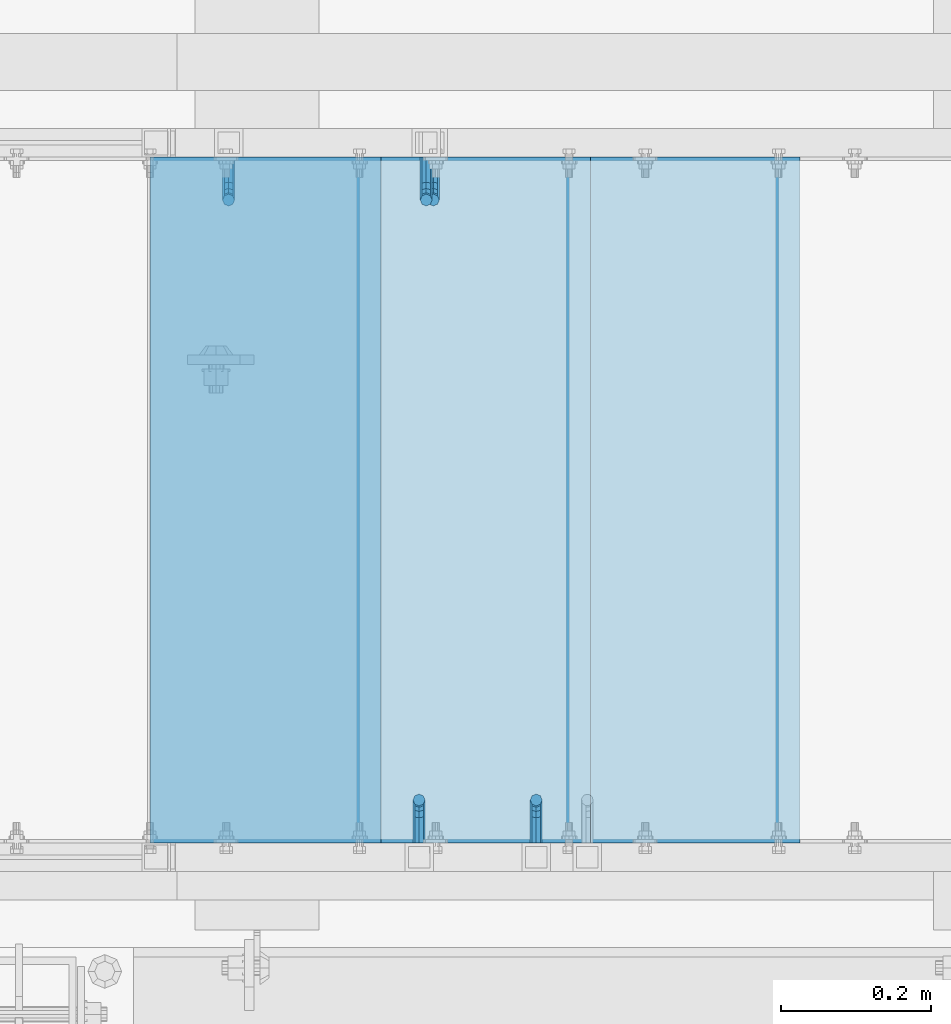
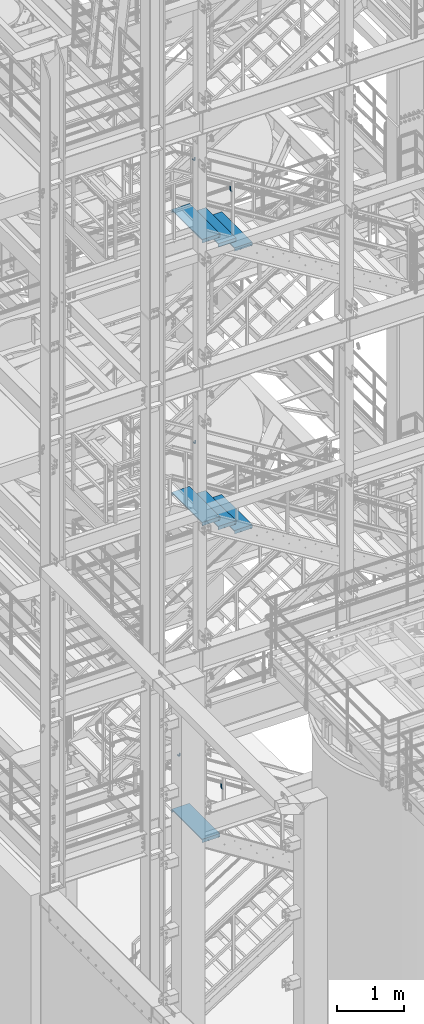
# One storey, part 1141 of 1876: 12 beams, 8 elements without a shape of their own.
"""IFC2X3 building model written with IfcOpenShell, lengths in millimetres."""

from ifc_helpers import new_model, si_unit, frame, origin_with_axes, place, context, subcontext, project, spatial, faceted_brep, material, type_object, element, aggregate, save


model = new_model("IFC2X3")

# Units and contexts
model_context = context("Model", 3, precision=1e-05, world=origin_with_axes())
body_context = subcontext(model_context, "Body", "Model", "MODEL_VIEW")
ifc_project = project(units=[si_unit("LENGTHUNIT", "METRE", prefix="MILLI"), si_unit("AREAUNIT", "SQUARE_METRE"), si_unit("VOLUMEUNIT", "CUBIC_METRE"), si_unit("MASSUNIT", "GRAM", prefix="KILO"), si_unit("TIMEUNIT", "SECOND"), si_unit("PLANEANGLEUNIT", "RADIAN"), si_unit("SOLIDANGLEUNIT", "STERADIAN"), si_unit("THERMODYNAMICTEMPERATUREUNIT", "DEGREE_CELSIUS"), si_unit("LUMINOUSINTENSITYUNIT", "LUMEN")], contexts=[model_context])

# Site, building, storey
site_placement = place(None, origin_with_axes())
site = spatial("IfcSite", under=ifc_project, at=site_placement, CompositionType="ELEMENT")
building_placement = place(site_placement, origin_with_axes())
building = spatial("IfcBuilding", under=site, at=building_placement, Name="Undefined", CompositionType="ELEMENT")
storey_placement = place(building_placement, origin_with_axes())
storey = spatial("IfcBuildingStorey", under=building, at=storey_placement, Name="Undefined", CompositionType="ELEMENT", Elevation=0.0)

# Assembly, beam
assembly_1_placement = place(storey_placement, origin_with_axes())
assembly_1 = element("IfcElementAssembly", 1, at=assembly_1_placement, inside=storey, Name="RAIL", AssemblyPlace="NOTDEFINED", PredefinedType="RIGID_FRAME")
ifc_material = material(Name="STEEL/A36")
beam_type_1 = type_object("IfcBeamType", PredefinedType="NOTDEFINED")
beam_1_placement = place(assembly_1_placement, frame((3073.40000611553, -6883.39999893226, 5224.5870754085), z_axis=(-1.0, 0.0, 0.0), x_axis=(0.0, 1.0, 0.0)))
beam_1 = element("IfcBeam", 2, at=beam_1_placement, type_object=beam_type_1, material=ifc_material, Name="BRACKET", context=body_context, shape_type="Brep", body=[
    faceted_brep([(0.0, -5.61266007566822, 5.61266007566883), (0.0, 0.0, 7.9375), (0.0, 5.61266007566822, 5.61266007566883), (0.0, 7.9375, 0.0), (0.0, 5.61266007566822, -5.61266007566883), (0.0, 0.0, -7.9375), (0.0, -5.61266007566822, -5.61266007566883), (0.0, -7.9375, 0.0), (23.8125, 5.61266007566883, 5.61266007566792), (23.8125, 7.9375, 0.0), (23.8125, 5.61266007566883, -5.61266007566792), (23.8125, 0.0, -7.9375), (23.8125, -5.61266007566883, -5.61266007566792), (23.8125, -7.9375, 0.0), (23.8125, -5.61266007566883, 5.61266007566792), (23.8125, 0.0, 7.9375), (36.5702095103989, -2.53766620105534, 7.9375), (38.7180815328547, 2.64775556579752, 5.61266007566792), (39.6077592547972, 4.79562758825296, 0.0), (38.7180815328547, 2.64775556579752, -5.61266007566792), (36.5702095103989, -2.53766620105534, -7.9375), (34.4223374879439, -7.72308796790867, -5.61266007566792), (33.5326597660014, -9.87095999036364, 0.0), (34.4223374879439, -7.72308796790867, 5.61266007566792), (43.4169233967659, -13.733078129113, 5.61266007566792), (47.385673396765, -9.76432812911298, 7.9375), (41.7730133210971, -15.3769882047809, 0.0), (43.4169233967659, -13.733078129113, -5.61266007566792), (47.385673396765, -9.76432812911298, -7.9375), (51.354423396765, -5.79557812911253, -5.61266007566792), (52.9983334724338, -4.15166805344461, 0.0), (51.354423396765, -5.79557812911253, 5.61266007566792), (54.6123353248231, -20.5797920154787, 7.9375), (59.7977570916764, -18.4319199930233, 5.61266007566792), (49.4269135579698, -22.7276640379341, 5.61266007566792), (47.2790415355148, -23.6173417598766, 0.0), (49.4269135579698, -22.7276640379341, -5.61266007566792), (54.6123353248231, -20.5797920154787, -7.9375), (59.7977570916764, -18.4319199930233, -5.61266007566792), (61.9456291141314, -17.5422422710808, 0.0), (62.7626616015468, -33.3375015258789, 5.61266007566792), (65.0875015258789, -33.3375015258789, 0.0), (57.1500015258789, -33.3375015258789, 7.9375), (51.5373414502101, -33.3375015258789, 5.61266007566792), (49.2125015258789, -33.3375015258789, 0.0), (51.5373414502101, -33.3375015258789, -5.61266007566792), (57.1500015258789, -33.3375015258789, -7.9375), (62.7626616015468, -33.3375015258789, -5.61266007566792), (65.0875015258789, -66.3399314131093, 0.0), (62.7626616015468, -62.779234846751, -5.61266007566792), (57.1500015258789, -61.3043460374702, -7.9375), (51.537341450211, -62.779234846751, -5.61266007566792), (49.2125015258789, -66.3399314131093, 0.0), (51.537341450211, -69.9006279794671, 5.61266007566792), (57.1500015258789, -71.375516788748, 7.9375), (62.7626616015468, -69.9006279794671, 5.61266007566792)], [[[0, 1, 2, 3, 4, 5, 6, 7]], [[3, 2, 8, 9]], [[4, 3, 9, 10]], [[5, 4, 10, 11]], [[6, 5, 11, 12]], [[7, 6, 12, 13]], [[0, 7, 13, 14]], [[1, 0, 14, 15]], [[2, 1, 15, 8]], [[8, 15, 16, 17]], [[9, 8, 17, 18]], [[10, 9, 18, 19]], [[11, 10, 19, 20]], [[12, 11, 20, 21]], [[13, 12, 21, 22]], [[14, 13, 22, 23]], [[15, 14, 23, 16]], [[23, 24, 25, 16]], [[22, 26, 24, 23]], [[21, 27, 26, 22]], [[20, 28, 27, 21]], [[19, 29, 28, 20]], [[18, 30, 29, 19]], [[17, 31, 30, 18]], [[16, 25, 31, 17]], [[25, 32, 33, 31]], [[24, 34, 32, 25]], [[26, 35, 34, 24]], [[27, 36, 35, 26]], [[28, 37, 36, 27]], [[29, 38, 37, 28]], [[30, 39, 38, 29]], [[31, 33, 39, 30]], [[33, 40, 41, 39]], [[32, 42, 40, 33]], [[34, 43, 42, 32]], [[35, 44, 43, 34]], [[36, 45, 44, 35]], [[37, 46, 45, 36]], [[38, 47, 46, 37]], [[39, 41, 47, 38]], [[47, 41, 48, 49]], [[46, 47, 49, 50]], [[45, 46, 50, 51]], [[44, 45, 51, 52]], [[43, 44, 52, 53]], [[42, 43, 53, 54]], [[40, 42, 54, 55]], [[41, 40, 55, 48]], [[54, 53, 52, 51, 50, 49, 48, 55]]]),
])
aggregate(assembly_1, [beam_1])

assembly_2_placement = place(storey_placement, origin_with_axes())
assembly_2 = element("IfcElementAssembly", 3, at=assembly_2_placement, inside=storey, Name="RAIL", AssemblyPlace="NOTDEFINED", PredefinedType="RIGID_FRAME")
beam_2_placement = place(assembly_2_placement, frame((3092.45000068742, -5969.00000114554, 11007.9367081082), z_axis=(-1.0, 0.0, 0.0), x_axis=(0.0, -1.0, 0.0)))
beam_2 = element("IfcBeam", 4, at=beam_2_placement, type_object=beam_type_1, material=ifc_material, Name="BRACKET", context=body_context, shape_type="Brep", body=[
    faceted_brep([(0.0, -5.61266007566822, 5.61266007566883), (0.0, 0.0, 7.9375), (0.0, 5.61266007566822, 5.61266007566883), (0.0, 7.9375, 0.0), (0.0, 5.61266007566822, -5.61266007566883), (0.0, 0.0, -7.9375), (0.0, -5.61266007566822, -5.61266007566883), (0.0, -7.9375, 0.0), (23.8125, -5.61266007566883, -5.61266007566792), (23.8125, -7.9375, 0.0), (23.8125, -5.61266007566883, 5.61266007566792), (23.8125, 0.0, 7.9375), (23.8125, 5.61266007566883, 5.61266007566792), (23.8125, 7.9375, 0.0), (23.8125, 5.61266007566883, -5.61266007566792), (23.8125, 0.0, -7.9375), (36.5702095103998, 2.53766620105671, -7.9375), (38.7180815328556, -2.64775556579843, -5.61266007566792), (39.6077592547981, -4.79562758825341, 0.0), (38.7180815328556, -2.64775556579843, 5.61266007566792), (36.5702095103998, 2.53766620105671, 7.9375), (34.4223374879448, 7.72308796790821, 5.61266007566792), (33.5326597660023, 9.87095999036319, 0.0), (34.4223374879448, 7.72308796790821, -5.61266007566792), (43.4169233967659, 13.733078129113, -5.61266007566792), (47.3856733967659, 9.76432812911298, -7.9375), (41.773013321098, 15.3769882047818, 0.0), (43.4169233967659, 13.733078129113, 5.61266007566792), (47.3856733967659, 9.76432812911298, 7.9375), (51.3544233967659, 5.79557812911298, 5.61266007566792), (52.9983334724348, 4.15166805344415, 0.0), (51.3544233967659, 5.79557812911298, -5.61266007566792), (54.6123353248231, 20.5797920154801, -7.9375), (59.7977570916764, 18.4319199930251, -5.61266007566792), (49.4269135579698, 22.727664037935, -5.61266007566792), (47.2790415355148, 23.6173417598766, 0.0), (49.4269135579698, 22.727664037935, 5.61266007566792), (54.6123353248231, 20.5797920154801, 7.9375), (59.7977570916764, 18.4319199930251, 5.61266007566792), (61.9456291141314, 17.5422422710835, 0.0), (62.7626616015468, 33.3375015258789, -5.61266007566792), (65.0875015258789, 33.3375015258789, 0.0), (57.1500015258789, 33.3375015258789, -7.9375), (51.5373414502101, 33.3375015258789, -5.61266007566792), (49.2125015258789, 33.3375015258789, 0.0), (51.5373414502101, 33.3375015258789, 5.61266007566792), (57.1500015258789, 33.3375015258789, 7.9375), (62.7626616015468, 33.3375015258789, 5.61266007566792), (65.0875015258789, 66.616627667634, 0.0), (62.7626616015468, 70.0692642717895, 5.61266007566837), (57.1500015258789, 71.4993931791778, 7.9375), (51.537341450211, 70.0692642717895, 5.61266007566837), (49.2125015258789, 66.616627667634, 0.0), (51.537341450211, 63.1639910634785, -5.61266007566837), (57.1500015258789, 61.7338621560921, -7.9375), (62.7626616015468, 63.1639910634785, -5.61266007566837)], [[[0, 1, 2, 3, 4, 5, 6, 7]], [[7, 6, 8, 9]], [[0, 7, 9, 10]], [[1, 0, 10, 11]], [[2, 1, 11, 12]], [[3, 2, 12, 13]], [[4, 3, 13, 14]], [[5, 4, 14, 15]], [[6, 5, 15, 8]], [[8, 15, 16, 17]], [[9, 8, 17, 18]], [[10, 9, 18, 19]], [[11, 10, 19, 20]], [[12, 11, 20, 21]], [[13, 12, 21, 22]], [[14, 13, 22, 23]], [[15, 14, 23, 16]], [[23, 24, 25, 16]], [[22, 26, 24, 23]], [[21, 27, 26, 22]], [[20, 28, 27, 21]], [[19, 29, 28, 20]], [[18, 30, 29, 19]], [[17, 31, 30, 18]], [[16, 25, 31, 17]], [[25, 32, 33, 31]], [[24, 34, 32, 25]], [[26, 35, 34, 24]], [[27, 36, 35, 26]], [[28, 37, 36, 27]], [[29, 38, 37, 28]], [[30, 39, 38, 29]], [[31, 33, 39, 30]], [[33, 40, 41, 39]], [[32, 42, 40, 33]], [[34, 43, 42, 32]], [[35, 44, 43, 34]], [[36, 45, 44, 35]], [[37, 46, 45, 36]], [[38, 47, 46, 37]], [[39, 41, 47, 38]], [[47, 41, 48, 49]], [[46, 47, 49, 50]], [[45, 46, 50, 51]], [[44, 45, 51, 52]], [[43, 44, 52, 53]], [[42, 43, 53, 54]], [[40, 42, 54, 55]], [[41, 40, 55, 48]], [[54, 53, 52, 51, 50, 49, 48, 55]]]),
])
aggregate(assembly_2, [beam_2])

assembly_3_placement = place(storey_placement, origin_with_axes())
assembly_3 = element("IfcElementAssembly", 5, at=assembly_3_placement, inside=storey, Name="RAIL", AssemblyPlace="NOTDEFINED", PredefinedType="RIGID_FRAME")
beam_3_placement = place(assembly_3_placement, frame((3082.92500086548, -5969.00000114554, 16184.4075685021), z_axis=(-1.0, 0.0, 0.0), x_axis=(0.0, -1.0, 0.0)))
beam_3 = element("IfcBeam", 6, at=beam_3_placement, type_object=beam_type_1, material=ifc_material, Name="BRACKET", context=body_context, shape_type="Brep", body=[
    faceted_brep([(0.0, -5.61266007566822, 5.61266007566883), (0.0, 0.0, 7.9375), (0.0, 5.61266007566822, 5.61266007566883), (0.0, 7.9375, 0.0), (0.0, 5.61266007566822, -5.61266007566883), (0.0, 0.0, -7.9375), (0.0, -5.61266007566822, -5.61266007566883), (0.0, -7.9375, 0.0), (23.8125, -5.61266007566883, -5.61266007566792), (23.8125, -7.9375, 0.0), (23.8125, -5.61266007566883, 5.61266007566792), (23.8125, 0.0, 7.9375), (23.8125, 5.61266007566883, 5.61266007566792), (23.8125, 7.9375, 0.0), (23.8125, 5.61266007566883, -5.61266007566792), (23.8125, 0.0, -7.9375), (36.5702095103998, 2.53766620105671, -7.9375), (38.7180815328556, -2.64775556579843, -5.61266007566792), (39.6077592547981, -4.79562758825341, 0.0), (38.7180815328556, -2.64775556579843, 5.61266007566792), (36.5702095103998, 2.53766620105671, 7.9375), (34.4223374879448, 7.72308796790821, 5.61266007566792), (33.5326597660023, 9.87095999036319, 0.0), (34.4223374879448, 7.72308796790821, -5.61266007566792), (43.4169233967659, 13.733078129113, -5.61266007566792), (47.3856733967659, 9.76432812911298, -7.9375), (41.773013321098, 15.3769882047818, 0.0), (43.4169233967659, 13.733078129113, 5.61266007566792), (47.3856733967659, 9.76432812911298, 7.9375), (51.3544233967659, 5.79557812911298, 5.61266007566792), (52.9983334724348, 4.15166805344415, 0.0), (51.3544233967659, 5.79557812911298, -5.61266007566792), (54.6123353248231, 20.5797920154801, -7.9375), (59.7977570916764, 18.4319199930251, -5.61266007566792), (49.4269135579698, 22.727664037935, -5.61266007566792), (47.2790415355148, 23.6173417598766, 0.0), (49.4269135579698, 22.727664037935, 5.61266007566792), (54.6123353248231, 20.5797920154801, 7.9375), (59.7977570916764, 18.4319199930251, 5.61266007566792), (61.9456291141314, 17.5422422710835, 0.0), (62.7626616015468, 33.3375015258789, -5.61266007566792), (65.0875015258789, 33.3375015258789, 0.0), (57.1500015258789, 33.3375015258789, -7.9375), (51.5373414502101, 33.3375015258789, -5.61266007566792), (49.2125015258789, 33.3375015258789, 0.0), (51.5373414502101, 33.3375015258789, 5.61266007566792), (57.1500015258789, 33.3375015258789, 7.9375), (62.7626616015468, 33.3375015258789, 5.61266007566792), (65.0875015258789, 66.5774551740215, 0.0), (62.7626616015468, 70.0546586046949, 5.61266007566792), (57.1500015258789, 71.4949634248096, 7.9375), (51.537341450211, 70.0546586046949, 5.61266007566792), (49.2125015258789, 66.5774551740215, 0.0), (51.537341450211, 63.1002517433481, -5.61266007566792), (57.1500015258789, 61.6599469232333, -7.9375), (62.7626616015468, 63.1002517433481, -5.61266007566792)], [[[0, 1, 2, 3, 4, 5, 6, 7]], [[7, 6, 8, 9]], [[0, 7, 9, 10]], [[1, 0, 10, 11]], [[2, 1, 11, 12]], [[3, 2, 12, 13]], [[4, 3, 13, 14]], [[5, 4, 14, 15]], [[6, 5, 15, 8]], [[8, 15, 16, 17]], [[9, 8, 17, 18]], [[10, 9, 18, 19]], [[11, 10, 19, 20]], [[12, 11, 20, 21]], [[13, 12, 21, 22]], [[14, 13, 22, 23]], [[15, 14, 23, 16]], [[23, 24, 25, 16]], [[22, 26, 24, 23]], [[21, 27, 26, 22]], [[20, 28, 27, 21]], [[19, 29, 28, 20]], [[18, 30, 29, 19]], [[17, 31, 30, 18]], [[16, 25, 31, 17]], [[25, 32, 33, 31]], [[24, 34, 32, 25]], [[26, 35, 34, 24]], [[27, 36, 35, 26]], [[28, 37, 36, 27]], [[29, 38, 37, 28]], [[30, 39, 38, 29]], [[31, 33, 39, 30]], [[33, 40, 41, 39]], [[32, 42, 40, 33]], [[34, 43, 42, 32]], [[35, 44, 43, 34]], [[36, 45, 44, 35]], [[37, 46, 45, 36]], [[38, 47, 46, 37]], [[39, 41, 47, 38]], [[47, 41, 48, 49]], [[46, 47, 49, 50]], [[45, 46, 50, 51]], [[44, 45, 51, 52]], [[43, 44, 52, 53]], [[42, 43, 53, 54]], [[40, 42, 54, 55]], [[41, 40, 55, 48]], [[54, 53, 52, 51, 50, 49, 48, 55]]]),
])
aggregate(assembly_3, [beam_3])

assembly_4_placement = place(storey_placement, origin_with_axes())
assembly_4 = element("IfcElementAssembly", 7, at=assembly_4_placement, inside=storey, Name="RAIL", AssemblyPlace="NOTDEFINED", PredefinedType="RIGID_FRAME")
beam_4_placement = place(assembly_4_placement, frame((3229.61000069266, -6883.39999885446, 16093.5319813663), z_axis=(-1.0, 0.0, 0.0), x_axis=(0.0, 1.0, 0.0)))
beam_4 = element("IfcBeam", 8, at=beam_4_placement, type_object=beam_type_1, material=ifc_material, Name="BRACKET", context=body_context, shape_type="Brep", body=[
    faceted_brep([(0.0, -5.61266007566822, 5.61266007566883), (0.0, 0.0, 7.9375), (0.0, 5.61266007566822, 5.61266007566883), (0.0, 7.9375, 0.0), (0.0, 5.61266007566822, -5.61266007566883), (0.0, 0.0, -7.9375), (0.0, -5.61266007566822, -5.61266007566883), (0.0, -7.9375, 0.0), (23.8125, 5.61266007566883, 5.61266007566792), (23.8125, 7.9375, 0.0), (23.8125, 5.61266007566883, -5.61266007566792), (23.8125, 0.0, -7.9375), (23.8125, -5.61266007566883, -5.61266007566792), (23.8125, -7.9375, 0.0), (23.8125, -5.61266007566883, 5.61266007566792), (23.8125, 0.0, 7.9375), (36.5702095103989, -2.53766620105534, 7.9375), (38.7180815328547, 2.64775556579752, 5.61266007566792), (39.6077592547972, 4.79562758825296, 0.0), (38.7180815328547, 2.64775556579752, -5.61266007566792), (36.5702095103989, -2.53766620105534, -7.9375), (34.4223374879439, -7.72308796790867, -5.61266007566792), (33.5326597660014, -9.87095999036364, 0.0), (34.4223374879439, -7.72308796790867, 5.61266007566792), (43.4169233967659, -13.733078129113, 5.61266007566792), (47.385673396765, -9.76432812911298, 7.9375), (41.7730133210971, -15.3769882047809, 0.0), (43.4169233967659, -13.733078129113, -5.61266007566792), (47.385673396765, -9.76432812911298, -7.9375), (51.354423396765, -5.79557812911253, -5.61266007566792), (52.9983334724338, -4.15166805344461, 0.0), (51.354423396765, -5.79557812911253, 5.61266007566792), (54.6123353248231, -20.5797920154787, 7.9375), (59.7977570916764, -18.4319199930233, 5.61266007566792), (49.4269135579698, -22.7276640379341, 5.61266007566792), (47.2790415355148, -23.6173417598766, 0.0), (49.4269135579698, -22.7276640379341, -5.61266007566792), (54.6123353248231, -20.5797920154787, -7.9375), (59.7977570916764, -18.4319199930233, -5.61266007566792), (61.9456291141314, -17.5422422710808, 0.0), (62.7626616015468, -33.3375015258789, 5.61266007566792), (65.0875015258789, -33.3375015258789, 0.0), (57.1500015258789, -33.3375015258789, 7.9375), (51.5373414502101, -33.3375015258789, 5.61266007566792), (49.2125015258789, -33.3375015258789, 0.0), (51.5373414502101, -33.3375015258789, -5.61266007566792), (57.1500015258789, -33.3375015258789, -7.9375), (62.7626616015468, -33.3375015258789, -5.61266007566792), (65.0875015258789, -66.4903966648035, 0.0), (62.7626616015468, -63.0131930011103, -5.61266007566792), (57.1500015258789, -61.5728880844745, -7.9375), (51.537341450211, -63.0131930011103, -5.61266007566792), (49.2125015258789, -66.4903966648035, 0.0), (51.537341450211, -69.9676003284985, 5.61266007566792), (57.1500015258789, -71.4079052451343, 7.9375), (62.7626616015468, -69.9676003284985, 5.61266007566792)], [[[0, 1, 2, 3, 4, 5, 6, 7]], [[3, 2, 8, 9]], [[4, 3, 9, 10]], [[5, 4, 10, 11]], [[6, 5, 11, 12]], [[7, 6, 12, 13]], [[0, 7, 13, 14]], [[1, 0, 14, 15]], [[2, 1, 15, 8]], [[8, 15, 16, 17]], [[9, 8, 17, 18]], [[10, 9, 18, 19]], [[11, 10, 19, 20]], [[12, 11, 20, 21]], [[13, 12, 21, 22]], [[14, 13, 22, 23]], [[15, 14, 23, 16]], [[23, 24, 25, 16]], [[22, 26, 24, 23]], [[21, 27, 26, 22]], [[20, 28, 27, 21]], [[19, 29, 28, 20]], [[18, 30, 29, 19]], [[17, 31, 30, 18]], [[16, 25, 31, 17]], [[25, 32, 33, 31]], [[24, 34, 32, 25]], [[26, 35, 34, 24]], [[27, 36, 35, 26]], [[28, 37, 36, 27]], [[29, 38, 37, 28]], [[30, 39, 38, 29]], [[31, 33, 39, 30]], [[33, 40, 41, 39]], [[32, 42, 40, 33]], [[34, 43, 42, 32]], [[35, 44, 43, 34]], [[36, 45, 44, 35]], [[37, 46, 45, 36]], [[38, 47, 46, 37]], [[39, 41, 47, 38]], [[47, 41, 48, 49]], [[46, 47, 49, 50]], [[45, 46, 50, 51]], [[44, 45, 51, 52]], [[43, 44, 52, 53]], [[42, 43, 53, 54]], [[40, 42, 54, 55]], [[41, 40, 55, 48]], [[54, 53, 52, 51, 50, 49, 48, 55]]]),
])
aggregate(assembly_4, [beam_4])

assembly_5_placement = place(storey_placement, origin_with_axes())
assembly_5 = element("IfcElementAssembly", 9, at=assembly_5_placement, inside=storey, Name="RAIL", AssemblyPlace="NOTDEFINED", PredefinedType="RIGID_FRAME")
beam_5_placement = place(assembly_5_placement, frame((2819.4000045896, -5969.00000106773, 5384.70957717574), z_axis=(-1.0, 0.0, 0.0), x_axis=(0.0, -1.0, 0.0)))
beam_5 = element("IfcBeam", 10, at=beam_5_placement, type_object=beam_type_1, material=ifc_material, Name="BRACKET", context=body_context, shape_type="Brep", body=[
    faceted_brep([(0.0, -5.61266007566822, 5.61266007566883), (0.0, 0.0, 7.9375), (0.0, 5.61266007566822, 5.61266007566883), (0.0, 7.9375, 0.0), (0.0, 5.61266007566822, -5.61266007566883), (0.0, 0.0, -7.9375), (0.0, -5.61266007566822, -5.61266007566883), (0.0, -7.9375, 0.0), (23.8125, -5.61266007566883, -5.61266007566792), (23.8125, -7.9375, 0.0), (23.8125, -5.61266007566883, 5.61266007566792), (23.8125, 0.0, 7.9375), (23.8125, 5.61266007566883, 5.61266007566792), (23.8125, 7.9375, 0.0), (23.8125, 5.61266007566883, -5.61266007566792), (23.8125, 0.0, -7.9375), (36.5702095103998, 2.53766620105671, -7.9375), (38.7180815328556, -2.64775556579843, -5.61266007566792), (39.6077592547981, -4.79562758825341, 0.0), (38.7180815328556, -2.64775556579843, 5.61266007566792), (36.5702095103998, 2.53766620105671, 7.9375), (34.4223374879448, 7.72308796790821, 5.61266007566792), (33.5326597660023, 9.87095999036319, 0.0), (34.4223374879448, 7.72308796790821, -5.61266007566792), (43.4169233967659, 13.733078129113, -5.61266007566792), (47.3856733967659, 9.76432812911298, -7.9375), (41.773013321098, 15.3769882047818, 0.0), (43.4169233967659, 13.733078129113, 5.61266007566792), (47.3856733967659, 9.76432812911298, 7.9375), (51.3544233967659, 5.79557812911298, 5.61266007566792), (52.9983334724348, 4.15166805344415, 0.0), (51.3544233967659, 5.79557812911298, -5.61266007566792), (54.6123353248231, 20.5797920154801, -7.9375), (59.7977570916764, 18.4319199930251, -5.61266007566792), (49.4269135579698, 22.727664037935, -5.61266007566792), (47.2790415355148, 23.6173417598766, 0.0), (49.4269135579698, 22.727664037935, 5.61266007566792), (54.6123353248231, 20.5797920154801, 7.9375), (59.7977570916764, 18.4319199930251, 5.61266007566792), (61.9456291141314, 17.5422422710835, 0.0), (62.7626616015468, 33.3375015258789, -5.61266007566792), (65.0875015258789, 33.3375015258789, 0.0), (57.1500015258789, 33.3375015258789, -7.9375), (51.5373414502101, 33.3375015258789, -5.61266007566792), (49.2125015258789, 33.3375015258789, 0.0), (51.5373414502101, 33.3375015258789, 5.61266007566792), (57.1500015258789, 33.3375015258789, 7.9375), (62.7626616015468, 33.3375015258789, 5.61266007566792), (65.0875015258789, 67.3558732176816, 0.0), (62.7626616015468, 70.9165696288755, 5.61266007566837), (57.1500015258789, 72.3914583738861, 7.9375), (51.537341450211, 70.9165696288755, 5.61266007566837), (49.2125015258789, 67.3558732176816, 0.0), (51.537341450211, 63.7951768064877, -5.61266007566837), (57.1500015258789, 62.3202880614781, -7.9375), (62.7626616015468, 63.7951768064877, -5.61266007566837)], [[[0, 1, 2, 3, 4, 5, 6, 7]], [[7, 6, 8, 9]], [[0, 7, 9, 10]], [[1, 0, 10, 11]], [[2, 1, 11, 12]], [[3, 2, 12, 13]], [[4, 3, 13, 14]], [[5, 4, 14, 15]], [[6, 5, 15, 8]], [[8, 15, 16, 17]], [[9, 8, 17, 18]], [[10, 9, 18, 19]], [[11, 10, 19, 20]], [[12, 11, 20, 21]], [[13, 12, 21, 22]], [[14, 13, 22, 23]], [[15, 14, 23, 16]], [[23, 24, 25, 16]], [[22, 26, 24, 23]], [[21, 27, 26, 22]], [[20, 28, 27, 21]], [[19, 29, 28, 20]], [[18, 30, 29, 19]], [[17, 31, 30, 18]], [[16, 25, 31, 17]], [[25, 32, 33, 31]], [[24, 34, 32, 25]], [[26, 35, 34, 24]], [[27, 36, 35, 26]], [[28, 37, 36, 27]], [[29, 38, 37, 28]], [[30, 39, 38, 29]], [[31, 33, 39, 30]], [[33, 40, 41, 39]], [[32, 42, 40, 33]], [[34, 43, 42, 32]], [[35, 44, 43, 34]], [[36, 45, 44, 35]], [[37, 46, 45, 36]], [[38, 47, 46, 37]], [[39, 41, 47, 38]], [[47, 41, 48, 49]], [[46, 47, 49, 50]], [[45, 46, 50, 51]], [[44, 45, 51, 52]], [[43, 44, 52, 53]], [[42, 43, 53, 54]], [[40, 42, 54, 55]], [[41, 40, 55, 48]], [[54, 53, 52, 51, 50, 49, 48, 55]]]),
])
aggregate(assembly_5, [beam_5])

# Assembly, beams
assembly_6_placement = place(storey_placement, origin_with_axes())
assembly_6 = element("IfcElementAssembly", 11, at=assembly_6_placement, inside=storey, Name="STRINGER", AssemblyPlace="NOTDEFINED", PredefinedType="RIGID_FRAME")
beam_type_2 = type_object("IfcBeamType", PredefinedType="NOTDEFINED")
beam_6_placement = place(assembly_6_placement, frame((3148.01250124689, -5973.76300114745, 15213.6592592597), z_axis=(1.0, 0.0, 0.0), x_axis=(0.0, -1.0, 0.0)))
beam_6 = element("IfcBeam", 12, at=beam_6_placement, type_object=beam_type_2, material=ifc_material, Name="TREAD", context=body_context, shape_type="Brep", body=[
    faceted_brep([(-7.45785655453801e-11, 53.9750000000167, -153.9875), (-7.45785655453801e-11, 53.9750000000167, 153.987506103515), (0.0, 9.52499999999964, 153.9875), (-7.45785655453801e-11, 9.52499999999964, -153.9875), (-4.76300000007541, 53.9750000000167, -153.9875), (-4.76300000007541, 53.9750000000167, 153.987506103515), (-4.76300000007541, -9.52499999998327, -153.9875), (-4.76300000007541, -9.52500000019427, 153.987536621094), (909.637000008669, -9.52500000248983, 153.987506103515), (909.637000008669, 53.9749999975102, 153.987506103515), (904.87400000867, 53.9749999975102, 153.987506103515), (904.87400000867, 9.52499999999964, 153.987506103515), (-7.45785655453801e-11, -9.52500000019427, 153.987536621094), (904.87400000867, -9.52500000248983, 153.987506103515), (904.87400000867, 9.52499999999964, -153.9875), (909.637000008669, -9.52500000248983, -153.9875), (909.637000008669, 53.9749999975102, -153.9875), (904.87400000867, 53.9749999975102, -153.9875)], [[[0, 1, 2, 3]], [[1, 0, 4, 5]], [[5, 4, 6, 7]], [[8, 9, 10, 11, 2, 1, 5, 7, 12, 13]], [[14, 3, 2, 11]], [[15, 8, 13, 12, 7, 6]], [[9, 16, 17, 10]], [[16, 9, 8, 15]], [[16, 15, 6, 4, 0, 3, 14, 17]], [[10, 17, 14, 11]]]),
])
beam_7_placement = place(assembly_6_placement, frame((3427.41250116849, -5973.76300114726, 15040.5629629634), z_axis=(1.0, 0.0, 0.0), x_axis=(0.0, -1.0, 0.0)))
beam_7 = element("IfcBeam", 13, at=beam_7_placement, type_object=beam_type_2, material=ifc_material, Name="TREAD", context=body_context, shape_type="Brep", body=[
    faceted_brep([(-7.45785655453801e-11, 53.9750000000167, -153.9875), (-7.45785655453801e-11, 53.9750000000167, 153.987506103515), (0.0, 9.52499999999964, 153.9875), (-7.45785655453801e-11, 9.52499999999964, -153.9875), (-4.76300000007541, 53.9750000000167, -153.9875), (-4.76300000007541, 53.9750000000167, 153.987506103515), (-4.76300000007541, -9.52499999998327, -153.9875), (-4.76300000007541, -9.52500000019427, 153.987536621094), (909.637000008669, 53.9749999975102, 153.987506103515), (904.87400000867, 53.9749999975102, 153.987506103515), (904.87400000867, 9.52499999999964, 153.987506103515), (909.637000008669, -9.52500000248983, 153.987506103515), (904.87400000867, 9.52499999999964, -153.9875), (909.637000008669, -9.52500000248983, -153.9875), (909.637000008669, 53.9749999975102, -153.9875), (904.87400000867, 53.9749999975102, -153.9875)], [[[0, 1, 2, 3]], [[1, 0, 4, 5]], [[5, 4, 6, 7]], [[8, 9, 10, 2, 1, 5, 7, 11]], [[12, 3, 2, 10]], [[13, 11, 7, 6]], [[8, 14, 15, 9]], [[14, 8, 11, 13]], [[14, 13, 6, 4, 0, 3, 12, 15]], [[9, 15, 12, 10]]]),
])
beam_8_placement = place(assembly_6_placement, frame((2868.61250132529, -5973.76300114757, 15386.755555556), z_axis=(1.0, 0.0, 0.0), x_axis=(0.0, -1.0, 0.0)))
beam_8 = element("IfcBeam", 14, at=beam_8_placement, type_object=beam_type_2, material=ifc_material, Name="TREAD", context=body_context, shape_type="Brep", body=[
    faceted_brep([(-7.45785655453801e-11, 53.9750000000167, -153.9875), (-7.45785655453801e-11, 53.9750000000167, 153.987506103515), (0.0, 9.52499999999964, 153.9875), (-7.45785655453801e-11, 9.52499999999964, -153.9875), (-4.76300000007541, 53.9750000000167, -153.9875), (-4.76300000007541, 53.9750000000167, 153.987506103515), (-4.76300000007541, -9.52499999998327, -153.9875), (-4.76300000007541, -9.52500000019427, 153.987536621094), (909.637000008669, 53.9749999975102, 153.987506103515), (904.87400000867, 53.9749999975102, 153.987506103515), (904.87400000867, 9.52499999999964, 153.987506103515), (909.637000008669, -9.52500000248983, 153.987506103515), (904.87400000867, 9.52499999999964, -153.9875), (909.637000008669, -9.52500000248983, -153.9875), (909.637000008669, 53.9749999975102, -153.9875), (904.87400000867, 53.9749999975102, -153.9875)], [[[0, 1, 2, 3]], [[1, 0, 4, 5]], [[5, 4, 6, 7]], [[8, 9, 10, 2, 1, 5, 7, 11]], [[12, 3, 2, 10]], [[13, 11, 7, 6]], [[8, 14, 15, 9]], [[14, 8, 11, 13]], [[14, 13, 6, 4, 0, 3, 12, 15]], [[9, 15, 12, 10]]]),
])
aggregate(assembly_6, [beam_6, beam_7, beam_8])

assembly_7_placement = place(storey_placement, origin_with_axes())
assembly_7 = element("IfcElementAssembly", 15, at=assembly_7_placement, inside=storey, Name="STRINGER", AssemblyPlace="NOTDEFINED", PredefinedType="RIGID_FRAME")
beam_9_placement = place(assembly_7_placement, frame((2868.61250108083, -5973.76300114444, 10215.8800007678), z_axis=(1.0, 0.0, 0.0), x_axis=(0.0, -1.0, 0.0)))
beam_9 = element("IfcBeam", 16, at=beam_9_placement, type_object=beam_type_2, material=ifc_material, Name="TREAD", context=body_context, shape_type="Brep", body=[
    faceted_brep([(-7.45785655453801e-11, 53.9750000000167, -153.9875), (-7.45785655453801e-11, 53.9750000000167, 153.987506103515), (0.0, 9.52499999999964, 153.9875), (-7.45785655453801e-11, 9.52499999999964, -153.9875), (-4.76300000007541, 53.9750000000167, -153.9875), (-4.76300000007541, 53.9750000000167, 153.987506103515), (-4.76300000007541, -9.52499999998327, -153.9875), (-4.76300000007541, -9.52500000019427, 153.987536621094), (909.637000008669, -9.52500000248983, 153.987506103515), (909.637000008669, 53.9749999975102, 153.987506103515), (904.87400000867, 53.9749999975102, 153.987506103515), (904.87400000867, 9.52499999999964, 153.987506103515), (-7.45785655453801e-11, -9.52500000019427, 153.987536621094), (904.87400000867, -9.52500000248983, 153.987506103515), (904.87400000867, 9.52499999999964, -153.9875), (909.637000008669, -9.52500000248983, -153.9875), (909.637000008669, 53.9749999975102, -153.9875), (904.87400000867, 53.9749999975102, -153.9875)], [[[0, 1, 2, 3]], [[1, 0, 4, 5]], [[5, 4, 6, 7]], [[8, 9, 10, 11, 2, 1, 5, 7, 12, 13]], [[14, 3, 2, 11]], [[15, 8, 13, 12, 7, 6]], [[9, 16, 17, 10]], [[16, 9, 8, 15]], [[16, 15, 6, 4, 0, 3, 14, 17]], [[10, 17, 14, 11]]]),
])
beam_10_placement = place(assembly_7_placement, frame((3148.01250101129, -5973.7630011447, 10044.0066673706), z_axis=(1.0, 0.0, 0.0), x_axis=(0.0, -1.0, 0.0)))
beam_10 = element("IfcBeam", 17, at=beam_10_placement, type_object=beam_type_2, material=ifc_material, Name="TREAD", context=body_context, shape_type="Brep", body=[
    faceted_brep([(-7.45785655453801e-11, 53.9750000000167, -153.9875), (-7.45785655453801e-11, 53.9750000000167, 153.987506103515), (0.0, 9.52499999999964, 153.9875), (-7.45785655453801e-11, 9.52499999999964, -153.9875), (-4.76300000007541, 53.9750000000167, -153.9875), (-4.76300000007541, 53.9750000000167, 153.987506103515), (-4.76300000007541, -9.52499999998327, -153.9875), (-4.76300000007541, -9.52500000019427, 153.987536621094), (909.637000008669, -9.52500000248983, 153.987506103515), (909.637000008669, 53.9749999975102, 153.987506103515), (904.87400000867, 53.9749999975102, 153.987506103515), (904.87400000867, 9.52499999999964, 153.987506103515), (-7.45785655453801e-11, -9.52500000019427, 153.987536621094), (904.87400000867, -9.52500000248983, 153.987506103515), (904.87400000867, 9.52499999999964, -153.9875), (909.637000008669, -9.52500000248983, -153.9875), (909.637000008669, 53.9749999975102, -153.9875), (904.87400000867, 53.9749999975102, -153.9875)], [[[0, 1, 2, 3]], [[1, 0, 4, 5]], [[5, 4, 6, 7]], [[8, 9, 10, 11, 2, 1, 5, 7, 12, 13]], [[14, 3, 2, 11]], [[15, 8, 13, 12, 7, 6]], [[9, 16, 17, 10]], [[16, 9, 8, 15]], [[16, 15, 6, 4, 0, 3, 14, 17]], [[10, 17, 14, 11]]]),
])
beam_11_placement = place(assembly_7_placement, frame((3427.41250094175, -5973.76300114495, 9872.13333397344), z_axis=(1.0, 0.0, 0.0), x_axis=(0.0, -1.0, 0.0)))
beam_11 = element("IfcBeam", 18, at=beam_11_placement, type_object=beam_type_2, material=ifc_material, Name="TREAD", context=body_context, shape_type="Brep", body=[
    faceted_brep([(-7.45785655453801e-11, 53.9750000000167, -153.9875), (-7.45785655453801e-11, 53.9750000000167, 153.987506103515), (0.0, 9.52499999999964, 153.9875), (-7.45785655453801e-11, 9.52499999999964, -153.9875), (-4.76300000007541, 53.9750000000167, -153.9875), (-4.76300000007541, 53.9750000000167, 153.987506103515), (-4.76300000007541, -9.52499999998327, -153.9875), (-4.76300000007541, -9.52500000019427, 153.987536621094), (909.637000008669, -9.52500000248983, 153.987506103515), (909.637000008669, 53.9749999975102, 153.987506103515), (904.87400000867, 53.9749999975102, 153.987506103515), (904.87400000867, 9.52499999999964, 153.987506103515), (-7.45785655453801e-11, -9.52500000019427, 153.987536621094), (904.87400000867, -9.52500000248983, 153.987506103515), (904.87400000867, 9.52499999999964, -153.9875), (909.637000008669, -9.52500000248983, -153.9875), (909.637000008669, 53.9749999975102, -153.9875), (904.87400000867, 53.9749999975102, -153.9875)], [[[0, 1, 2, 3]], [[1, 0, 4, 5]], [[5, 4, 6, 7]], [[8, 9, 10, 11, 2, 1, 5, 7, 12, 13]], [[14, 3, 2, 11]], [[15, 8, 13, 12, 7, 6]], [[9, 16, 17, 10]], [[16, 9, 8, 15]], [[16, 15, 6, 4, 0, 3, 14, 17]], [[10, 17, 14, 11]]]),
])
aggregate(assembly_7, [beam_9, beam_10, beam_11])

# Assembly, beam
assembly_8_placement = place(storey_placement, origin_with_axes())
assembly_8 = element("IfcElementAssembly", 19, at=assembly_8_placement, inside=storey, Name="STRINGER", AssemblyPlace="NOTDEFINED", PredefinedType="RIGID_FRAME")
beam_12_placement = place(assembly_8_placement, frame((2868.61250483616, -5973.76300113373, 4421.78965517514), z_axis=(1.0, 0.0, 0.0), x_axis=(0.0, -1.0, 0.0)))
beam_12 = element("IfcBeam", 20, at=beam_12_placement, type_object=beam_type_2, material=ifc_material, Name="TREAD", context=body_context, shape_type="Brep", body=[
    faceted_brep([(-7.45785655453801e-11, 53.9750000000167, -153.9875), (-7.45785655453801e-11, 53.9750000000167, 153.987506103515), (0.0, 9.52499999999964, 153.9875), (-7.45785655453801e-11, 9.52499999999964, -153.9875), (-4.76300000007541, 53.9750000000167, -153.9875), (-4.76300000007541, 53.9750000000167, 153.987506103515), (-4.76300000007541, -9.52499999998327, -153.9875), (-4.76300000007541, -9.52500000019427, 153.987536621094), (909.637000008669, -9.52500000248983, 153.987506103515), (909.637000008669, 53.9749999975102, 153.987506103515), (904.87400000867, 53.9749999975102, 153.987506103515), (904.87400000867, 9.52499999999964, 153.987506103515), (-7.45785655453801e-11, -9.52500000019427, 153.987536621094), (904.87400000867, -9.52500000248983, 153.987506103515), (904.87400000867, 9.52499999999964, -153.9875), (909.637000008669, -9.52500000248983, -153.9875), (909.637000008669, 53.9749999975102, -153.9875), (904.87400000867, 53.9749999975102, -153.9875)], [[[0, 1, 2, 3]], [[1, 0, 4, 5]], [[5, 4, 6, 7]], [[8, 9, 10, 11, 2, 1, 5, 7, 12, 13]], [[14, 3, 2, 11]], [[15, 8, 13, 12, 7, 6]], [[9, 16, 17, 10]], [[16, 9, 8, 15]], [[16, 15, 6, 4, 0, 3, 14, 17]], [[10, 17, 14, 11]]]),
])
aggregate(assembly_8, [beam_12])

save(model, "model.ifc")
